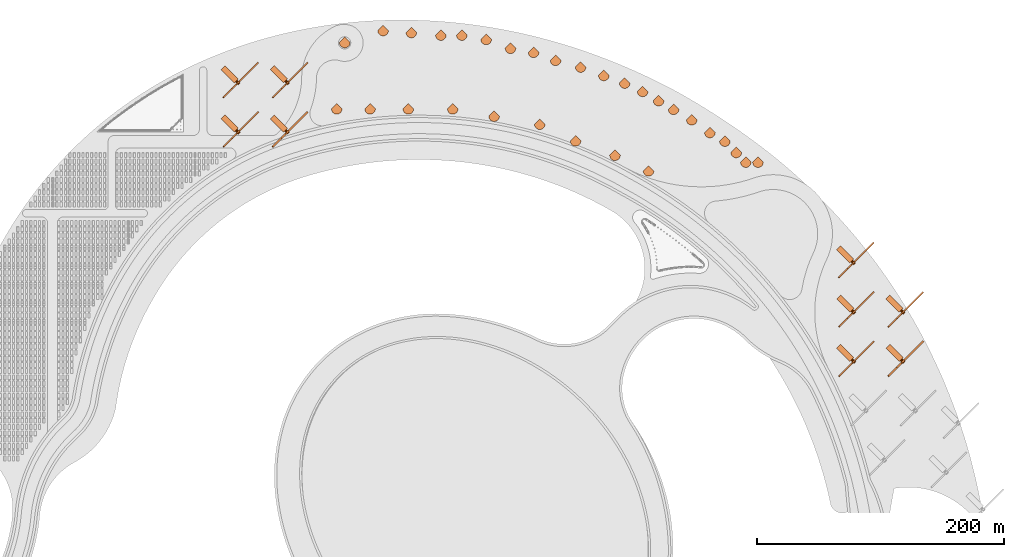
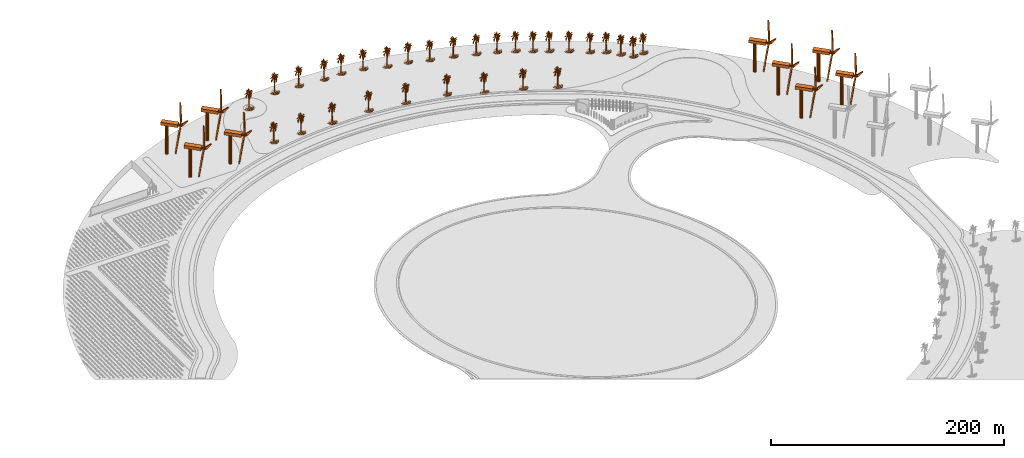
# One storey, part 39 of 39: 39 proxies.
"""IFC2X3 building model written with IfcOpenShell, lengths in millimetres."""

from ifc_helpers import new_model, entity, si_unit, converted_unit, derived_unit, direction, frame, frame_2d, origin, origin_2d_with_axis, place, context, subcontext, project, spatial, polyline, rectangle, circle, outline, extrude, face_set, surface_model, source, transform, mapped, material, element, save


model = new_model("IFC2X3")

# Units and contexts
model_context = context("Model", 3, precision=1e-06, world=origin(), true_north=direction((2.0, 6.12303176911189e-17, 1.0)))
context_of_model = context(None, 3, precision=1e-06, world=origin(), true_north=direction((2.0, 6.12303176911189e-17, 1.0)))
body_context = subcontext(model_context, "Body", "Model", "MODEL_VIEW")
ifc_project = project(units=[si_unit("LENGTHUNIT", "METRE", prefix="MILLI"), si_unit("AREAUNIT", "SQUARE_METRE", prefix="MILLI"), si_unit("VOLUMEUNIT", "CUBIC_METRE", prefix="MILLI"), converted_unit("PLANEANGLEUNIT", "DEGREE", entity("IfcRatioMeasure", 0.0174532925199433), si_unit("PLANEANGLEUNIT", "RADIAN"), dimensions=[0, 0, 0, 0, 0, 0, 0]), si_unit("MASSUNIT", "GRAM", prefix="KILO"), si_unit("TIMEUNIT", "SECOND"), si_unit("THERMODYNAMICTEMPERATUREUNIT", "KELVIN"), derived_unit("THERMALTRANSMITTANCEUNIT", [(si_unit("MASSUNIT", "GRAM", prefix="KILO"), 1), (si_unit("THERMODYNAMICTEMPERATUREUNIT", "KELVIN"), -1), (si_unit("TIMEUNIT", "SECOND"), -3)]), derived_unit("VOLUMETRICFLOWRATEUNIT", [(si_unit("LENGTHUNIT", "METRE"), 3), (si_unit("TIMEUNIT", "SECOND"), -1)])], contexts=[model_context, context_of_model])

# Site, building, storey
site_placement = place(None, origin())
site = spatial("IfcSite", under=ifc_project, at=site_placement, CompositionType="ELEMENT")
building_placement = place(site_placement, origin())
building = spatial("IfcBuilding", under=site, at=building_placement, CompositionType="ELEMENT")
storey_placement = place(building_placement, frame((0.0, 0.0, 4000.0)))
storey = spatial("IfcBuildingStorey", under=building, at=storey_placement, Name="Level 2", CompositionType="ELEMENT", Elevation=4000.0)

# Proxies
ifc_material = material(Name="Fiber")
shared_shape_1 = source(origin(), body_context, "Body", "SweptSolid", [
    extrude(circle(Radius=1219.2, at=frame_2d((-6.76791955811495e-14, 0.0), x_axis=(1.0, 0.0))), frame((9757.6692079255, 232.615468373865, 32004.0), z_axis=(1.0, 0.0, 0.0), x_axis=(0.0, 1.0, 0.0)), (0.0, 0.0, 1.0), 3530.39369698097),
    extrude(outline(polyline([(-25235.4928838689, -504.733169788446), (-23497.3886370042, -1390.34151744038), (-7977.11862314176, -3021.5876283642), (53.6807312814044, -2015.04698959787), (16924.7516619105, -20107.0555602115), (16387.0603591711, -18231.9031447106), (6995.27954346578, -5768.58904743497), (751.216457059019, -669.077510465183), (8466.50028987177, 23076.1245264183), (7087.13294967557, 21696.757186222), (739.698514629178, 7440.18602516133), (-695.320363049468, -504.733169788446), (-25235.4928838689, -504.733169788446)])), frame((11244.2702506938, 1002.10079122165, 31247.797146957), z_axis=(-1.0, 0.0, 0.0), x_axis=(0.0, 0.694658370459002, 0.719339800338647)), (0.0, 0.0, -1.0), 1219.2),
    extrude(rectangle(XDim=4611.80210432249, YDim=15240.0, at=origin_2d_with_axis()), frame((2137.6692079255, 256.362690579343, 30480.0), z_axis=(0.0, 0.0, 1.0), x_axis=(0.0, 1.0, 0.0)), (0.0, 0.0, 1.0), 3048.0),
    extrude(circle(Radius=1524.0, at=frame_2d((0.0, -2.47029063871196e-12), x_axis=(1.0, 0.0))), frame((-559.015649158661, 286.937889183146, 0.0)), (0.0, 0.0, 1.0), 30480.0),
])
for number, where, z_axis, x_axis, name in (
    (1, (-11947.3964746308, 712120.835289923, 0.0), (0.0, 0.0, 1.0), (0.707106781186547, -0.707106781186548, 0.0), "140_ft_tall_Wind_7978:140_ft_tall_Wind_7978"),
    (2, (28052.6035253693, 752120.835289923, 0.0), (0.0, 0.0, 1.0), (0.707106781186547, -0.707106781186548, 0.0), "140_ft_tall_Wind_7978:140_ft_tall_Wind_7978"),
    (3, (-11947.3964746307, 752120.835289923, 0.0), (0.0, 0.0, 1.0), (0.707106781186547, -0.707106781186548, 0.0), "140_ft_tall_Wind_7978:140_ft_tall_Wind_7978"),
    (4, (28052.6035253692, 712120.835289923, 0.0), (0.0, 0.0, 1.0), (0.707106781186547, -0.707106781186548, 0.0), "140_ft_tall_Wind_7978:140_ft_tall_Wind_7978"),
    (5, (486980.904039215, 606168.888693961, 0.0), (0.0, 0.0, 1.0), (0.707106781186547, -0.707106781186548, 0.0), "140_ft_tall_Wind_7978:140_ft_tall_Wind_7978"),
    (6, (486980.904039215, 566168.888693961, 0.0), (0.0, 0.0, 1.0), (0.707106781186547, -0.707106781186548, 0.0), "140_ft_tall_Wind_7978:140_ft_tall_Wind_7978"),
    (7, (526980.904039215, 566168.888693961, 0.0), (0.0, 0.0, 1.0), (0.707106781186547, -0.707106781186548, 0.0), "140_ft_tall_Wind_7978:140_ft_tall_Wind_7978"),
    (8, (486980.904039215, 526168.888693961, 0.0), (0.0, 0.0, 1.0), (0.707106781186547, -0.707106781186548, 0.0), "140_ft_tall_Wind_7978:140_ft_tall_Wind_7978"),
    (9, (526980.904039215, 526168.888693961, 0.0), (0.0, 0.0, 1.0), (0.707106781186547, -0.707106781186548, 0.0), "140_ft_tall_Wind_7978:140_ft_tall_Wind_7978"),
):
    element("IfcBuildingElementProxy", number, at=place(storey_placement, frame(where, z_axis=z_axis, x_axis=x_axis)), inside=storey, material=ifc_material, Name=name, ObjectType="140_ft_tall_Wind_7978", CompositionType="ELEMENT", context=body_context, shape_type="MappedRepresentation", body=[
        mapped(shared_shape_1, transform((0.0, 0.0, 0.0), scale=1.0)),
    ])
shared_shape_2 = source(origin(), body_context, "Body", "SurfaceModel", [
    surface_model("IfcFaceBasedSurfaceModel", [(1614.98165588379, -0.0491518181632273, 17645.1159851074), (2518.84770584106, -0.0492362198419869, 17896.1820556641), (1866.05484809876, -0.0491448190645315, 17544.7162994385), (259.179746818542, -0.0492452193167992, 18498.7813201904), (8.10526300817728, -0.0494048191700131, 19452.8475036621), (510.254174423218, -0.0492561526363716, 18498.7813201904), (-2854.1403213501, -0.0481034170486964, 12874.7211181641), (-3255.85998687744, -0.0478972851647995, 11820.1878112793), (-3105.22005386353, -0.0482002201722935, 13477.2529449463), (-2050.70128097534, -0.0481834853184409, 13125.7871887207), (-2753.71389312744, -0.0478025533840992, 11167.3892852783), (-594.47272567749, -0.0479866855661385, 11669.5214263916), (-845.549188041687, -0.0479218840249814, 11368.2549316406), (-544.258784866333, -0.0481325533473864, 12472.9875), (2468.6342010498, -0.0481744858436286, 11970.8553588867), (2267.77436828613, -0.0480489544803277, 11318.055670166), (1966.48796195984, -0.0482962204841897, 12774.253994751), (2167.34779472351, -0.0483139533083886, 12824.5206939697), (-343.398298072815, -0.0478809539345093, 11016.7229003906), (-745.115928840637, -0.047809552482795, 10715.4564056396), (-544.259438896179, -0.0479350173147395, 11368.2549316406), (2669.49403381348, -0.0486681529437192, 14682.4526367188), (2970.78058547974, -0.0485286854789592, 13828.786138916), (2368.20762748718, -0.0485741530079395, 14230.5197570801), (2518.84770584106, -0.0489040199085139, 16038.2512756348), (3623.57998352051, -0.0488894184934907, 15686.718081665), (2669.49403381348, -0.0487848844262771, 15335.2511627197), (-745.115928840637, -0.049048619158566, 17645.1159851074), (-544.258784866333, -0.0491831499966793, 18348.1149353027), (-192.754477214813, -0.0490458825021051, 17494.4496002197), (2920.56708068848, -0.0491998848505318, 17594.9155609131), (3472.93336486816, -0.0491791492444463, 17343.8494903564), (2820.14065246582, -0.0491146847954951, 17142.9826812744), (-3055.00015411377, -0.0485974833369255, 15686.718081665), (-4109.51253204346, -0.0485064861830324, 15435.6508483887), (-3808.2259803772, -0.0486094855936244, 15937.7841522217), (-2753.71389312744, -0.0487004871829413, 16188.9176605225), (-1648.98844642639, -0.0488385530537926, 16691.0498016357), (-2351.99437294006, -0.048852684313897, 16942.1170349121), (-1448.12861366272, -0.0489730173605494, 17394.0499145508), (1363.90860900879, -0.0486020873067901, 14632.2522125244), (1715.40822944641, -0.0485815512947738, 14431.3854034424), (1464.33518257141, -0.0485526190255769, 14330.919442749), (2066.91453552246, -0.049117683141958, 17343.8494903564), (2368.20762748718, -0.049041083373595, 16841.649911499), (-1598.76840133667, -0.0487778853275813, 16339.516607666), (-1900.06149330139, -0.0487826844560914, 16439.9837310791), (-745.115928840637, -0.0489768185187131, 17243.3823669434), (-42.1100204944611, -0.0488369518658146, 16289.3173461914), (-2753.71389312744, -0.04914041912416, 18649.4477050781), (-2803.92710723877, -0.0492190192686394, 19101.3805847168), (-2351.99437294006, -0.0492298195254989, 19051.113885498), (1614.98165588379, -0.0490620185737498, 17142.9826812744), (962.189016151428, -0.0490334854926914, 17142.9826812744), (-2603.0672744751, -0.0485813517007045, 15485.851272583), (-1598.76840133667, -0.0487240171059966, 16038.2512756348), (-1548.55518722534, -0.0486364174867049, 15536.1179718018), (-845.549188041687, -0.0486940868664533, 15686.718081665), (-895.762474822998, -0.0486290191998705, 15335.2511627197), (911.975729370117, -0.0488516863435507, 16138.6509613037), (208.964461612701, -0.048847885185387, 16289.3173461914), (-1950.27470741272, -0.0490318843047135, 17845.9827941895), (-1598.76840133667, -0.0491460166289471, 18398.3153594971), (-1197.04880847931, -0.0490468183765188, 17745.5156707764), (2117.12789497375, -0.0487158204428852, 15084.1850921631), (2016.70132141113, -0.0485857516410761, 14381.1187042236), (1614.98165588379, -0.0486579514690675, 14883.3182830811), (1614.98165588379, -0.0488375506480224, 15887.5837280273), (1213.26213569641, -0.0488110179430805, 15837.3844665527), (208.964461612701, -0.0490813525859267, 17594.9155609131), (660.899339675903, -0.0490652165142819, 17394.0499145508), (1715.40822944641, -0.048419884534087, 13527.519644165), (2267.77436828613, -0.0483632175601088, 13075.5867645264), (1966.48796195984, -0.048448816803284, 13627.919329834), (-996.195734024048, -0.0487323512672447, 15937.7841522217), (-2301.78101348877, -0.0484148858115077, 14481.5858276367), (-1498.34182777405, -0.0483782181632705, 14079.8522094727), (-192.754477214813, -0.0485968845547177, 14983.71796875), (309.394377994537, -0.0478915545972995, 10916.322052002), (359.609009170532, -0.045945286215283, 0.00245501093304483), (-142.539855122566, -0.045908019784838, 0.00247696434016689), (-393.614273643494, -0.0459302856121212, 0.0024879375785531), (-343.398988437653, -0.047081819199957, 6547.63347930908), (1263.47534980774, -0.0485348196700215, 14280.7190185547), (1966.48796195984, -0.0484757531317882, 13778.5868774414), (811.542470169067, -0.0485510178375989, 14481.5858276367), (1614.98165588379, -0.048631019575987, 14732.6518981934), (-293.184375429153, -0.0484039524919353, 13929.185824585), (761.329256057739, -0.0483692186884582, 13477.2529449463), (-694.902642059326, -0.0482786207227036, 13326.6539978027), (-393.613583278656, -0.0482199533726089, 12924.9203796387), (761.329256057739, -0.0481716870912351, 12372.5878143311), (510.254174423218, -0.0479452187893912, 11167.3892852783), (0.186937161767855, -7.72852592021227, 19076.9809112549), (0.186943495552987, -784.992564582825, 19999.9792236328), (0.186939290771261, -444.941554927826, 19562.7803283691), (0.186941827833653, -1319.36539764404, 12470.1876708984), (0.186935884365812, -1319.36539764404, 10381.3233123779), (0.186941561708227, -1173.63214187622, 11450.0557525635), (0.186943016527221, 2858.44383773804, 11790.1222045898), (0.186937623051926, 3441.38994140625, 10867.1227294922), (0.186941153649241, 2761.28407058716, 12713.1205169678), (0.186935689207166, -2582.42405776978, 17279.5162078857), (0.186940284306183, -4039.8025428772, 16890.9166717529), (0.186938616586849, -2776.74388275146, 16890.9166717529), (0.186938758520409, -1027.89234580994, 12324.4547058105), (0.186939893988892, 575.221429824829, 10964.2563354492), (0.186944950371981, 1061.0122718811, 9944.05697937012), (0.186941153649241, 1061.0122718811, 11158.588659668), (0.186937818210572, -153.465850639343, 18153.9814361572), (0.186938421428204, 2761.28407058716, 16988.05027771), (0.18694294556044, 3635.70976638794, 17085.2501586914), (0.18694069236517, 2761.28407058716, 17473.8496948242), (0.186942022992298, 2081.17790908814, 12761.6536010742), (0.186939823022112, 2907.02372131348, 14704.852432251), (0.186939947213978, 3830.02959136963, 14219.0530151367), (0.186936948867515, 3344.23656921387, 15287.7842926025), (0.186942679435015, -590.678734874725, 11109.9893005371), (0.186935689207166, -1027.89234580994, 9652.59046783447), (0.1869391488377, -590.678734874725, 9944.05697937012), (0.186937427893281, -153.465850639343, 10769.9228485107), (0.186941295582801, -3116.79696350098, 15773.5848724365), (0.18694294556044, -3748.32295074463, 15142.0513275147), (0.18693689564243, -3019.63690567017, 15142.0513275147), (0.186941827833653, 1401.06520729065, 19076.9809112549), (0.186939823022112, 915.272403144837, 19951.379864502), (0.186941827833653, 818.119176292419, 19659.9139343262), (0.186936558550224, 1109.59222812653, 16210.7837677002), (0.186936026299372, 2081.17790908814, 16745.183706665), (0.186944347154349, 1692.54494476318, 16890.9166717529), (0.186942093959078, 2809.8639541626, 15287.7842926025), (0.186937356926501, -1222.2054851532, 17911.0485900879), (0.186936221458018, -2048.05129737854, 18494.0478881836), (0.186936079524457, -2048.05129737854, 18056.7815551758), (0.186938084335998, -1805.15827445984, 17425.3166107178), (0.186941224616021, -3602.58969497681, 13004.5876098633), (0.186942218150944, -3165.37684707642, 12373.0540649414), (0.186941029457375, -2339.53103485107, 14121.9194091797), (0.186941685900092, -3262.53690490723, 13976.1864440918), (0.186938492394984, -1562.26510620117, 15239.2512084961), (0.186941756866872, -1173.63214187622, 15142.0513275147), (0.186940355272964, 2324.0710773468, 13781.8529571533), (0.186935955332592, 1401.06520729065, 14170.4524932861), (0.186940355272964, 1352.48532371521, 14753.4517913818), (0.186938084335998, 1012.43231563568, 14607.7188262939), (0.186941561708227, 575.221429824829, 19028.381552124), (0.186940213339403, 1741.12497367859, 17182.3826019287), (0.186935547273606, 915.272403144837, 16599.4507415771), (0.186942555243149, -2096.63118095398, 15433.5184204102), (0.186939627863467, -2193.79109344482, 16113.6501617432), (0.186938758520409, -1465.10519371033, 16016.5177185059), (0.186941348807886, 1303.91198043823, 17862.5155059814), (0.186940887523815, -1950.89807052612, 16550.8502197266), (0.186943158460781, -1756.57824554443, 16842.3161499023), (0.186937960144132, -1222.2054851532, 16405.1172546387), (0.186935955332592, -1222.2054851532, 16793.7830657959), (0.186937356926501, -639.25800075531, 17328.1155670166), (0.186944613279775, -299.204374980927, 16502.2508605957), (0.186943158460781, -250.625090932846, 6009.17390441895), (0.186936558550224, -250.625090932846, 0.00121222543166368), (0.18693882948719, 235.167095518112, 0.0012990920971788), (0.186937818210572, 429.48424987793, 0.00133383865249925), (0.186938758520409, 429.48424987793, 4794.69512786865), (0.186944081028923, 380.905638027191, 11255.722265625), (0.186940621398389, 2372.65096092224, 14607.7188262939), (0.186941224616021, 2615.54412918091, 16113.6501617432), (0.186939823022112, 1692.54494476318, 15919.3178375244), (0.186936221458018, 1789.6981716156, 14656.2519104004), (0.186938013369218, -639.25800075531, 13004.5876098633), (0.186942413309589, -1076.47222938538, 13976.1864440918), (0.186937552085146, -202.045134687424, 17328.1155670166), (0.186936079524457, 40.8505588531494, 15967.9171966553), (0.186940018180758, -542.099468994141, 12518.7870300293), (0.186941881058738, 1206.75214061737, 13198.919934082), (0.186944151995704, -299.204374980927, 15190.6518493652), (0.186939893988892, -1465.10519371033, 16259.3842895508), (4315.3458984375, -128.947870445251, 0.00104536562139401), (-11.6471167892218, 4198.04259338379, 0.000794539219714352), (-4338.63895339966, -128.947870445251, 0.00142363851919072), (4200.95259017944, -1120.40552158356, 0.000873079139455513), (-4224.2456451416, -1120.40552158356, 0.00124135216647119), (3875.16637115479, -2030.90466957092, 0.000724505957623478), (-3898.45942611694, -2030.90466957092, 0.00106430564319453), (-3387.36649475098, -2834.3572265625, 0.000898299097570998), (3364.07343978882, -2834.3572265625, 0.000603181385849894), (2693.76086654663, -3504.66979980469, 0.000512620150948351), (-2717.05392150879, -3504.66979980469, 0.000749132608507352), (-1913.60150985718, -4015.76273117065, 0.000622624065908894), (-1003.10904750824, -4341.54895019531, 0.000524569494427851), (-11.6463174194098, -4455.94225845337, 0.000460776873569557), (979.81570186615, -4341.54895019531, 0.000437893552134483), (1890.30816421509, -4015.76273117065, 0.000456349558317015)], [face_set([[[0, 1, 2]], [[3, 4, 5]], [[6, 7, 8]], [[9, 10, 6]], [[11, 12, 13]], [[14, 15, 16]], [[17, 14, 16]], [[18, 19, 20]], [[21, 22, 23]], [[24, 25, 26]], [[27, 28, 29]], [[30, 31, 32]], [[33, 34, 35]], [[33, 35, 36]], [[37, 38, 39]], [[40, 41, 42]], [[43, 30, 32]], [[43, 32, 44]], [[45, 46, 37]], [[47, 27, 29]], [[47, 29, 48]], [[49, 50, 51]], [[0, 2, 52]], [[53, 0, 52]], [[54, 33, 36]], [[54, 36, 55]], [[56, 54, 55]], [[56, 55, 57]], [[58, 56, 57]], [[43, 44, 59]], [[52, 43, 59]], [[60, 53, 59]], [[61, 49, 51]], [[61, 51, 62]], [[61, 62, 63]], [[39, 61, 63]], [[39, 63, 47]], [[64, 21, 23]], [[64, 23, 65]], [[64, 65, 66]], [[67, 24, 26]], [[67, 26, 64]], [[68, 67, 66]], [[69, 3, 5]], [[69, 5, 70]], [[48, 69, 70]], [[48, 70, 60]], [[17, 16, 71]], [[72, 17, 71]], [[73, 72, 71]], [[74, 45, 48]], [[57, 74, 48]], [[9, 8, 75]], [[76, 9, 75]], [[76, 75, 58]], [[77, 76, 58]], [[78, 79, 80]], [[78, 80, 81]], [[78, 81, 82]], [[78, 82, 18]], [[73, 71, 83]], [[84, 73, 83]], [[42, 84, 83]], [[40, 83, 85]], [[77, 59, 68]], [[77, 66, 86]], [[77, 86, 40]], [[87, 77, 85]], [[87, 85, 88]], [[89, 87, 88]], [[90, 89, 88]], [[90, 88, 91]], [[13, 90, 91]], [[13, 91, 92]], [[20, 11, 92]], [[78, 18, 92]], [[93, 94, 95]], [[96, 97, 98]], [[99, 100, 101]], [[102, 103, 104]], [[96, 98, 105]], [[106, 107, 108]], [[93, 95, 109]], [[110, 111, 112]], [[113, 99, 101]], [[114, 115, 116]], [[117, 118, 119]], [[117, 119, 120]], [[121, 122, 123]], [[124, 125, 126]], [[127, 128, 129]], [[114, 116, 130]], [[131, 132, 133]], [[131, 133, 134]], [[135, 136, 137]], [[138, 135, 137]], [[139, 138, 137]], [[139, 137, 140]], [[113, 101, 141]], [[142, 113, 141]], [[142, 141, 143]], [[144, 142, 143]], [[124, 126, 145]], [[110, 112, 146]], [[129, 110, 146]], [[129, 146, 147]], [[121, 123, 148]], [[149, 121, 148]], [[150, 149, 148]], [[150, 148, 139]], [[151, 124, 145]], [[102, 104, 152]], [[153, 102, 152]], [[153, 152, 154]], [[155, 153, 154]], [[131, 134, 155]], [[156, 131, 155]], [[157, 156, 155]], [[158, 159, 160]], [[158, 160, 161]], [[158, 161, 162]], [[158, 162, 163]], [[120, 158, 163]], [[164, 114, 130]], [[130, 165, 166]], [[167, 164, 166]], [[143, 167, 166]], [[96, 105, 168]], [[169, 96, 168]], [[145, 93, 109]], [[151, 109, 170]], [[147, 151, 170]], [[147, 170, 171]], [[172, 117, 163]], [[143, 166, 127]], [[163, 106, 108]], [[163, 108, 173]], [[168, 172, 173]], [[168, 173, 144]], [[174, 169, 144]], [[150, 140, 174]], [[150, 171, 157]], [[150, 154, 175]], [[176, 177, 178]], [[179, 176, 178]], [[179, 178, 180]], [[181, 179, 180]], [[181, 180, 182]], [[181, 182, 183]], [[184, 181, 183]], [[185, 184, 183]], [[185, 183, 186]], [[185, 186, 187]], [[185, 187, 188]], [[185, 188, 189]], [[185, 189, 190]], [[185, 190, 191]]])]),
])
for number, where, name in (
    (10, (114144.808955034, 786301.520590507, 0.0), "M_RPC Tree - Tropical:Cuban Royal Palm - 7.5 Meters"),
    (11, (137088.78211101, 784697.121694392, 0.0), "M_RPC Tree - Tropical:Cuban Royal Palm - 7.5 Meters"),
    (12, (160997.454865212, 782605.383868449, 0.0), "M_RPC Tree - Tropical:Cuban Royal Palm - 7.5 Meters"),
    (13, (177997.454865212, 782605.383868449, 0.0), "M_RPC Tree - Tropical:Cuban Royal Palm - 7.5 Meters"),
    (14, (197693.609925456, 779132.42031511, 0.0), "M_RPC Tree - Tropical:Cuban Royal Palm - 7.5 Meters"),
    (15, (217427.15496196, 771949.997305271, 0.0), "M_RPC Tree - Tropical:Cuban Royal Palm - 7.5 Meters"),
    (16, (236138.502269192, 768650.681929599, 0.0), "M_RPC Tree - Tropical:Cuban Royal Palm - 7.5 Meters"),
    (17, (253992.662064124, 762152.299206411, 0.0), "M_RPC Tree - Tropical:Cuban Royal Palm - 7.5 Meters"),
    (18, (274277.104416194, 756717.099259258, 0.0), "M_RPC Tree - Tropical:Cuban Royal Palm - 7.5 Meters"),
    (19, (293070.956831913, 749876.696392745, 0.0), "M_RPC Tree - Tropical:Cuban Royal Palm - 7.5 Meters"),
    (20, (309985.424006059, 743720.333812883, 0.0), "M_RPC Tree - Tropical:Cuban Royal Palm - 7.5 Meters"),
    (21, (324486.348598645, 736958.441625031, 0.0), "M_RPC Tree - Tropical:Cuban Royal Palm - 7.5 Meters"),
    (22, (337476.729655412, 729458.441625031, 0.0), "M_RPC Tree - Tropical:Cuban Royal Palm - 7.5 Meters"),
    (23, (349601.085308394, 722458.441625031, 0.0), "M_RPC Tree - Tropical:Cuban Royal Palm - 7.5 Meters"),
    (24, (364323.517172729, 713958.441625031, 0.0), "M_RPC Tree - Tropical:Cuban Royal Palm - 7.5 Meters"),
    (25, (379068.253969931, 703634.065770712, 0.0), "M_RPC Tree - Tropical:Cuban Royal Palm - 7.5 Meters"),
    (26, (391192.609622913, 696634.065770712, 0.0), "M_RPC Tree - Tropical:Cuban Royal Palm - 7.5 Meters"),
    (27, (400384.997778338, 687441.677615287, 0.0), "M_RPC Tree - Tropical:Cuban Royal Palm - 7.5 Meters"),
    (28, (408163.17237139, 679663.503022235, 0.0), "M_RPC Tree - Tropical:Cuban Royal Palm - 7.5 Meters"),
    (29, (418003.578374511, 679663.503022235, 0.0), "M_RPC Tree - Tropical:Cuban Royal Palm - 7.5 Meters"),
    (30, (83071.2908794575, 776623.039767765, 0.0), "M_RPC Tree - Tropical:Cuban Royal Palm - 7.5 Meters"),
    (31, (76592.3704912391, 722839.327160172, 0.0), "M_RPC Tree - Tropical:Cuban Royal Palm - 7.5 Meters"),
    (32, (103592.370491239, 722839.327160171, 0.0), "M_RPC Tree - Tropical:Cuban Royal Palm - 7.5 Meters"),
    (33, (134592.370491239, 722839.327160171, 0.0), "M_RPC Tree - Tropical:Cuban Royal Palm - 7.5 Meters"),
    (34, (170592.370491239, 722839.327160171, 0.0), "M_RPC Tree - Tropical:Cuban Royal Palm - 7.5 Meters"),
    (35, (204146.525812474, 716922.824262155, 0.0), "M_RPC Tree - Tropical:Cuban Royal Palm - 7.5 Meters"),
    (36, (241160.653188647, 710396.234938356, 0.0), "M_RPC Tree - Tropical:Cuban Royal Palm - 7.5 Meters"),
    (37, (270162.50237382, 696872.450562653, 0.0), "M_RPC Tree - Tropical:Cuban Royal Palm - 7.5 Meters"),
    (38, (302112.051480541, 685243.76568958, 0.0), "M_RPC Tree - Tropical:Cuban Royal Palm - 7.5 Meters"),
    (39, (329301.28509164, 672565.217837359, 0.0), "M_RPC Tree - Tropical:Cuban Royal Palm - 7.5 Meters"),
):
    element("IfcBuildingElementProxy", number, at=place(storey_placement, frame(where)), inside=storey, Name=name, ObjectType="Cuban Royal Palm - 7.5 Meters", CompositionType="ELEMENT", context=body_context, shape_type="MappedRepresentation", body=[
        mapped(shared_shape_2, transform((0.0, 0.0, 0.0), scale=1.0)),
    ])

save(model, "model.ifc")
